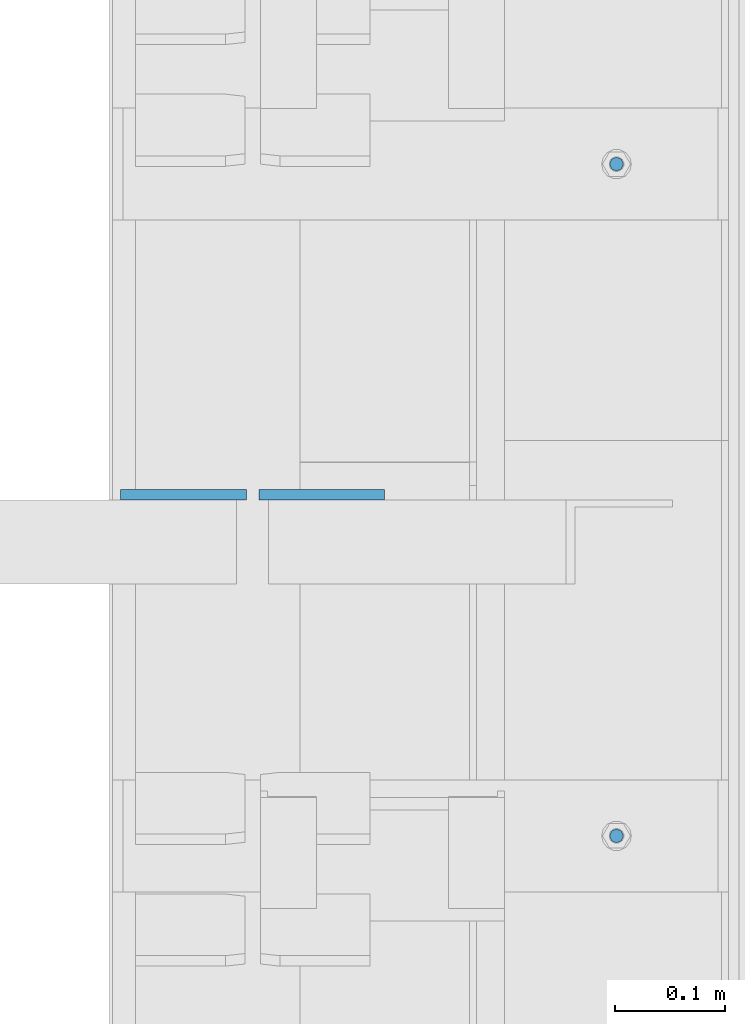
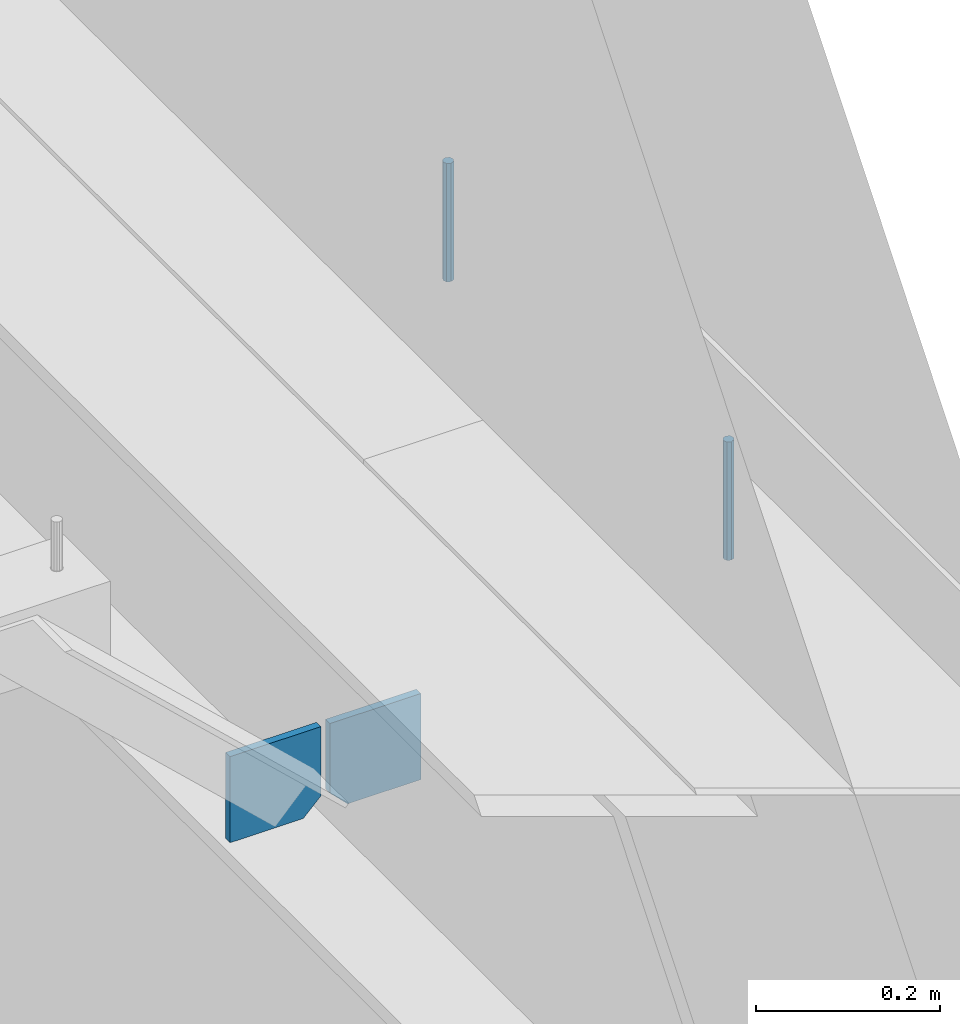
# One storey, part 449 of 1179: 4 columns, 1 element without a shape of its own.
"""IFC2X3 building model written with IfcOpenShell, lengths in millimetres."""

from ifc_helpers import new_model, si_unit, frame, origin_with_axes, place, context, subcontext, project, spatial, faceted_brep, material, type_object, element, aggregate, save


model = new_model("IFC2X3")

# Units and contexts
model_context = context("Model", 3, precision=1e-05, world=origin_with_axes())
body_context = subcontext(model_context, "Body", "Model", "MODEL_VIEW")
ifc_project = project(units=[si_unit("LENGTHUNIT", "METRE", prefix="MILLI"), si_unit("AREAUNIT", "SQUARE_METRE"), si_unit("VOLUMEUNIT", "CUBIC_METRE"), si_unit("MASSUNIT", "GRAM", prefix="KILO"), si_unit("TIMEUNIT", "SECOND"), si_unit("PLANEANGLEUNIT", "RADIAN"), si_unit("SOLIDANGLEUNIT", "STERADIAN"), si_unit("THERMODYNAMICTEMPERATUREUNIT", "DEGREE_CELSIUS"), si_unit("LUMINOUSINTENSITYUNIT", "LUMEN")], contexts=[model_context])

# Site, building, storey
site_placement = place(None, origin_with_axes())
site = spatial("IfcSite", under=ifc_project, at=site_placement, CompositionType="ELEMENT")
building_placement = place(site_placement, origin_with_axes())
building = spatial("IfcBuilding", under=site, at=building_placement, Name="Undefined", CompositionType="ELEMENT")
storey_placement = place(building_placement, origin_with_axes())
storey = spatial("IfcBuildingStorey", under=building, at=storey_placement, Name="Undefined", CompositionType="ELEMENT", Elevation=0.0)

# Assembly, columns
assembly_placement = place(storey_placement, origin_with_axes())
assembly = element("IfcElementAssembly", 1, at=assembly_placement, inside=storey, Name="BEAM", AssemblyPlace="NOTDEFINED", PredefinedType="RIGID_FRAME")
ifc_material_1 = material(Name="STEEL/A36")
column_type_1 = type_object("IfcColumnType", PredefinedType="NOTDEFINED")
column_1_placement = place(assembly_placement, frame((24245.09375, 22229.7625, 3702.05), z_axis=(1.0, 0.0, 0.0), x_axis=(0.0, 0.0, 1.0)))
column_1 = element("IfcColumn", 2, at=column_1_placement, type_object=column_type_1, material=ifc_material_1, Name="PLATE", context=body_context, shape_type="Brep", body=[
    faceted_brep([(22.2250000000004, 4.76250000000073, 57.1500000000015), (0.0, 4.76250000000073, 34.9249999999993), (0.0, -4.76250000000073, 34.9249999999993), (22.2250000000004, -4.76250000000073, 57.1500000000015), (114.300000000001, 4.76250000000073, 57.1500000000015), (114.300000000001, 4.76250000000073, -57.1500000000015), (0.0, 4.76250000000073, -57.1500000000015), (114.300000000001, -4.76250000000073, 57.1500000000015), (0.0, -4.76250000000073, -57.1500000000015), (114.300000000001, -4.76250000000073, -57.1500000000015)], [[[0, 1, 2, 3]], [[4, 5, 6, 1, 0]], [[7, 4, 0, 3]], [[8, 9, 7, 3, 2]], [[8, 6, 5, 9]], [[7, 9, 5, 4]], [[6, 8, 2, 1]]]),
])
column_2_placement = place(assembly_placement, frame((24370.50625, 22229.7625, 3702.05), z_axis=(-1.0, 0.0, 0.0), x_axis=(0.0, 0.0, 1.0)))
column_2 = element("IfcColumn", 3, at=column_2_placement, type_object=column_type_1, material=ifc_material_1, Name="PLATE", context=body_context, shape_type="Brep", body=[
    faceted_brep([(22.2250000000004, 4.76250000000073, 57.1500000000015), (0.0, 4.76250000000073, 34.9249999999993), (0.0, -4.76250000000073, 34.9249999999993), (22.2250000000004, -4.76250000000073, 57.1500000000015), (114.300000000001, 4.76250000000073, 57.1500000000015), (114.300000000001, 4.76250000000073, -57.1500000000015), (0.0, 4.76250000000073, -57.1500000000015), (114.300000000001, -4.76250000000073, 57.1500000000015), (0.0, -4.76250000000073, -57.1500000000015), (114.300000000001, -4.76250000000073, -57.1500000000015)], [[[0, 1, 2, 3]], [[4, 5, 6, 1, 0]], [[7, 4, 0, 3]], [[8, 9, 7, 3, 2]], [[8, 6, 5, 9]], [[7, 9, 5, 4]], [[6, 8, 2, 1]]]),
])
ifc_material_2 = material(Name="STEEL/A307")
column_type_2 = type_object("IfcColumnType", PredefinedType="NOTDEFINED")
column_3_placement = place(assembly_placement, frame((24638.0, 22529.8, 4108.45), z_axis=(0.0, 1.0, 0.0), x_axis=(0.0, 0.0, 1.0)))
column_3 = element("IfcColumn", 4, at=column_3_placement, type_object=column_type_2, material=ifc_material_2, Name="THREADED ROD", context=body_context, shape_type="Brep", body=[
    faceted_brep([(0.0, -6.34999999999854, 0.0), (0.0, -4.49012806053361, -4.49012806053452), (157.162499999999, -4.49012806053361, -4.49012806053361), (157.162499999999, -6.34999999999854, 0.0), (0.0, 0.0, -6.34999999999991), (157.162499999999, 0.0, -6.34999999999854), (0.0, 4.49012806053361, -4.49012806053452), (157.162499999999, 4.49012806053361, -4.49012806053361), (0.0, 6.34999999999854, 0.0), (157.162499999999, 6.34999999999854, 0.0), (0.0, 4.49012806053361, 4.49012806053452), (157.162499999999, 4.49012806053361, 4.49012806053361), (0.0, 0.0, 6.34999999999991), (157.162499999999, 0.0, 6.34999999999854), (0.0, -4.49012806053361, 4.49012806053452), (157.162499999999, -4.49012806053361, 4.49012806053361)], [[[0, 1, 2, 3]], [[1, 4, 5, 2]], [[4, 6, 7, 5]], [[6, 8, 9, 7]], [[8, 10, 11, 9]], [[10, 12, 13, 11]], [[12, 14, 15, 13]], [[14, 0, 3, 15]], [[5, 7, 9, 11, 13, 15, 3, 2]], [[14, 12, 10, 8, 6, 4, 1, 0]]]),
])
column_4_placement = place(assembly_placement, frame((24638.0, 21920.2, 4108.45), z_axis=(0.0, 1.0, 0.0), x_axis=(0.0, 0.0, 1.0)))
column_4 = element("IfcColumn", 5, at=column_4_placement, type_object=column_type_2, material=ifc_material_2, Name="THREADED ROD", context=body_context, shape_type="Brep", body=[
    faceted_brep([(0.0, -6.34999999999854, 0.0), (0.0, -4.49012806053361, -4.49012806053452), (157.162499999999, -4.49012806053361, -4.49012806053361), (157.162499999999, -6.34999999999854, 0.0), (0.0, 0.0, -6.34999999999991), (157.162499999999, 0.0, -6.34999999999854), (0.0, 4.49012806053361, -4.49012806053452), (157.162499999999, 4.49012806053361, -4.49012806053361), (0.0, 6.34999999999854, 0.0), (157.162499999999, 6.34999999999854, 0.0), (0.0, 4.49012806053361, 4.49012806053452), (157.162499999999, 4.49012806053361, 4.49012806053361), (0.0, 0.0, 6.34999999999991), (157.162499999999, 0.0, 6.34999999999854), (0.0, -4.49012806053361, 4.49012806053452), (157.162499999999, -4.49012806053361, 4.49012806053361)], [[[0, 1, 2, 3]], [[1, 4, 5, 2]], [[4, 6, 7, 5]], [[6, 8, 9, 7]], [[8, 10, 11, 9]], [[10, 12, 13, 11]], [[12, 14, 15, 13]], [[14, 0, 3, 15]], [[5, 7, 9, 11, 13, 15, 3, 2]], [[14, 12, 10, 8, 6, 4, 1, 0]]]),
])
aggregate(assembly, [column_3, column_4, column_1, column_2])

save(model, "model.ifc")
